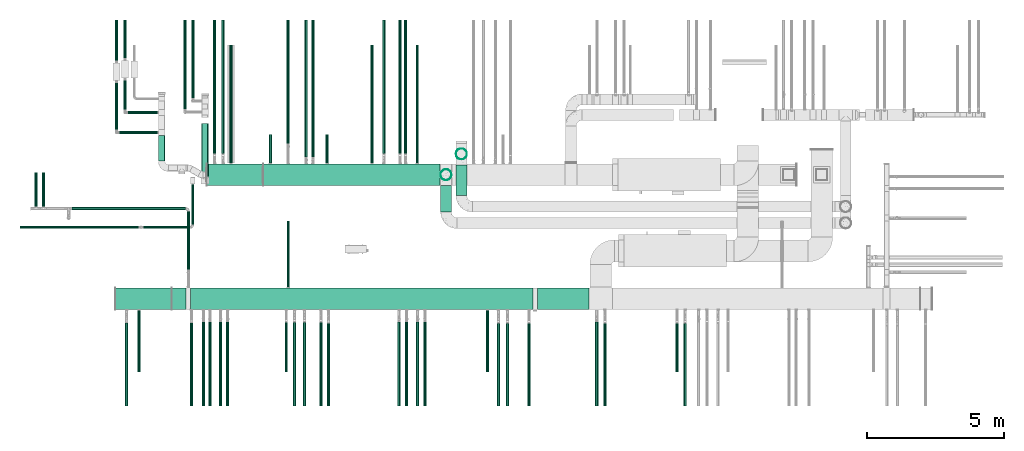
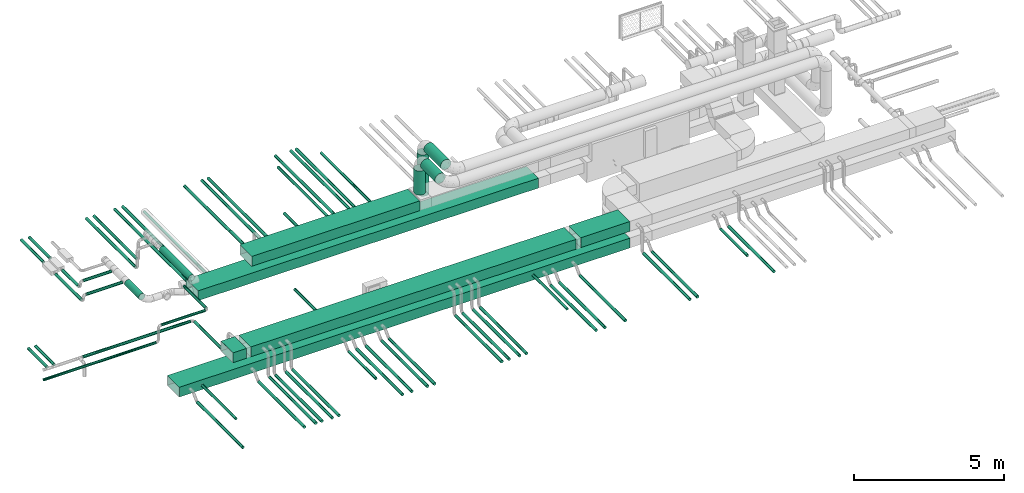
# One storey, part 2 of 91: 65 flow segments.
"""IFC2X3 building model written with IfcOpenShell, lengths in millimetres."""

from ifc_helpers import new_model, entity, si_unit, converted_unit, derived_unit, direction, frame, origin_with_axes, origin_2d_with_axis, place, context, subcontext, project, spatial, hollow_rectangle, hollow_circle, extrude, source, transform, mapped, material, layer, layer_set, layer_usage, type_object, element, save


model = new_model("IFC2X3")

# Units and contexts
model_context = context("Model", 3, precision=1e-05, world=origin_with_axes(), true_north=direction((0.0, 1.0)))
body_context = subcontext(model_context, "Body", "Model", "MODEL_VIEW")
ifc_project = project(units=[si_unit("AREAUNIT", "SQUARE_METRE"), si_unit("VOLUMEUNIT", "CUBIC_METRE", prefix="DECI"), si_unit("TIMEUNIT", "SECOND"), si_unit("THERMODYNAMICTEMPERATUREUNIT", "DEGREE_CELSIUS"), si_unit("PRESSUREUNIT", "PASCAL"), si_unit("MASSUNIT", "GRAM", prefix="KILO"), si_unit("LENGTHUNIT", "METRE", prefix="MILLI"), si_unit("POWERUNIT", "WATT"), si_unit("ELECTRICCURRENTUNIT", "AMPERE"), si_unit("ELECTRICVOLTAGEUNIT", "VOLT"), derived_unit("VOLUMETRICFLOWRATEUNIT", [(si_unit("VOLUMEUNIT", "CUBIC_METRE", prefix="DECI"), 1), (si_unit("TIMEUNIT", "SECOND"), -1)]), derived_unit("LINEARVELOCITYUNIT", [(si_unit("LENGTHUNIT", "METRE"), 1), (si_unit("TIMEUNIT", "SECOND"), -1)]), derived_unit("MASSDENSITYUNIT", [(si_unit("MASSUNIT", "GRAM", prefix="KILO"), 1), (si_unit("VOLUMEUNIT", "CUBIC_METRE"), -1)]), converted_unit("PLANEANGLEUNIT", "DEGREE", entity("IfcRatioMeasure", 0.01745), si_unit("PLANEANGLEUNIT", "RADIAN"), dimensions=[0, 0, 0, 0, 0, 0, 0])], contexts=[model_context])

# Site, building, storey
site_placement = place(None, origin_with_axes())
site = spatial("IfcSite", under=ifc_project, at=site_placement, CompositionType="ELEMENT")
building_placement = place(site_placement, origin_with_axes())
building = spatial("IfcBuilding", under=site, at=building_placement, Name="mc-building", CompositionType="ELEMENT")
storey_placement = place(building_placement, frame((0.0, 0.0, 8700.0), z_axis=(0.0, 0.0, 1.0), x_axis=(1.0, 0.0, 0.0)))
storey = spatial("IfcBuildingStorey", under=building, at=storey_placement, CompositionType="ELEMENT", Elevation=8700.0)

# Flow segments
ifc_material_1 = material(Name="FZ1")
ifc_layer_1 = layer(ifc_material_1, 0.0)
ifc_layer_set_1 = layer_set([ifc_layer_1], Name="FZ1")
ifc_layer_usage_1 = layer_usage(ifc_layer_set_1, "AXIS1", "POSITIVE", 0.0)
duct_segment_type_1 = type_object("IfcDuctSegmentType", PredefinedType="RIGIDSEGMENT")
shared_shape_1 = source(origin_with_axes(), body_context, "Body", "SweptSolid", [
    extrude(hollow_circle(Radius=50.0, WallThickness=2.0, at=origin_2d_with_axis()), frame((0.0, 0.0, 0.0), z_axis=(1.0, 0.0, 0.0), x_axis=(0.0, 1.0, 0.0)), (0.0, 0.0, 1.0), 2257.3),
])
for number, where, z_axis, x_axis in (
    (1, (6000.0, 673.88887, 668.0), (0.0, 0.0, 1.0), (0.0, 1.0, 0.0)),
    (2, (18753.74821, 673.88887, 668.0), (0.0, 0.0, 1.0), (0.0, 1.0, 0.0)),
):
    element("IfcFlowSegment", number, at=place(storey_placement, frame(where, z_axis=z_axis, x_axis=x_axis)), inside=storey, type_object=duct_segment_type_1, material=ifc_layer_usage_1, context=body_context, shape_type="MappedRepresentation", body=[
        mapped(shared_shape_1, transform((0.0, 0.0, 0.0), scale=1.0)),
    ])
shared_shape_2 = source(origin_with_axes(), body_context, "Body", "SweptSolid", [
    extrude(hollow_circle(Radius=55.0, WallThickness=2.0, at=origin_2d_with_axis()), frame((0.0, 0.0, 0.0), z_axis=(1.0, 0.0, 0.0), x_axis=(0.0, 1.0, 0.0)), (0.0, 0.0, 1.0), 2847.2),
])
flow_segment_1_placement = place(storey_placement, frame((7969.21808, 13553.57591, 415.0), z_axis=(0.0, 0.0, 1.0), x_axis=(0.0, -1.0, 0.0)))
element("IfcFlowSegment", 3, at=flow_segment_1_placement, inside=storey, type_object=duct_segment_type_1, material=ifc_layer_usage_1, context=body_context, shape_type="MappedRepresentation", body=[
    mapped(shared_shape_2, transform((0.0, 0.0, 0.0), scale=1.0)),
])
shared_shape_3 = source(origin_with_axes(), body_context, "Body", "SweptSolid", [
    extrude(hollow_circle(Radius=55.0, WallThickness=2.0, at=origin_2d_with_axis()), frame((0.0, 0.0, 0.0), z_axis=(1.0, 0.0, 0.0), x_axis=(0.0, 1.0, 0.0)), (0.0, 0.0, 1.0), 1388.6),
])
flow_segment_2_placement = place(storey_placement, frame((5487.14677, 13553.57591, 415.0), z_axis=(0.0, 0.0, 1.0), x_axis=(0.0, -1.0, 0.0)))
element("IfcFlowSegment", 4, at=flow_segment_2_placement, inside=storey, type_object=duct_segment_type_1, material=ifc_layer_usage_1, context=body_context, shape_type="MappedRepresentation", body=[
    mapped(shared_shape_3, transform((0.0, 0.0, 0.0), scale=1.0)),
])
ifc_material_2 = material(Name="1")
ifc_layer_2 = layer(ifc_material_2, 0.0)
ifc_layer_set_2 = layer_set([ifc_layer_2], Name="1")
ifc_layer_usage_2 = layer_usage(ifc_layer_set_2, "AXIS1", "POSITIVE", 0.0)
duct_segment_type_2 = type_object("IfcDuctSegmentType", PredefinedType="RIGIDSEGMENT")
shared_shape_4 = source(origin_with_axes(), body_context, "Body", "SweptSolid", [
    extrude(hollow_rectangle(XDim=800.0, YDim=400.0, WallThickness=2.0, at=origin_2d_with_axis()), frame((0.0, 0.0, 0.0), z_axis=(1.0, 0.0, 0.0), x_axis=(0.0, 1.0, 0.0)), (0.0, 0.0, 1.0), 12528.3),
])
flow_segment_3_placement = place(storey_placement, frame((20412.5937, 3351.20513, 1344.0), z_axis=(0.0, 0.0, 1.0), x_axis=(-1.0, 0.0, 0.0)))
element("IfcFlowSegment", 5, at=flow_segment_3_placement, inside=storey, type_object=duct_segment_type_2, material=ifc_layer_usage_2, context=body_context, shape_type="MappedRepresentation", body=[
    mapped(shared_shape_4, transform((0.0, 0.0, 0.0), scale=1.0)),
])
shared_shape_5 = source(origin_with_axes(), body_context, "Body", "SweptSolid", [
    extrude(hollow_rectangle(XDim=800.0, YDim=400.0, WallThickness=2.0, at=origin_2d_with_axis()), frame((0.0, 0.0, 0.0), z_axis=(1.0, 0.0, 0.0), x_axis=(0.0, 1.0, 0.0)), (0.0, 0.0, 1.0), 17341.2),
])
flow_segment_4_placement = place(storey_placement, frame((22475.0, 3351.20513, 668.0), z_axis=(0.0, 0.0, 1.0), x_axis=(-1.0, 0.0, 0.0)))
element("IfcFlowSegment", 6, at=flow_segment_4_placement, inside=storey, type_object=duct_segment_type_2, material=ifc_layer_usage_2, context=body_context, shape_type="MappedRepresentation", body=[
    mapped(shared_shape_5, transform((0.0, 0.0, 0.0), scale=1.0)),
])
shared_shape_6 = source(origin_with_axes(), body_context, "Body", "SweptSolid", [
    extrude(hollow_circle(Radius=55.0, WallThickness=2.0, at=origin_2d_with_axis()), frame((0.0, 0.0, 0.0), z_axis=(1.0, 0.0, 0.0), x_axis=(0.0, 1.0, 0.0)), (0.0, 0.0, 1.0), 1699.9),
])
flow_segment_5_placement = place(storey_placement, frame((5177.14677, 11247.78475, 415.0), z_axis=(0.0, 0.0, 1.0), x_axis=(0.0, -1.0, 0.0)))
element("IfcFlowSegment", 7, at=flow_segment_5_placement, inside=storey, type_object=duct_segment_type_1, material=ifc_layer_usage_1, context=body_context, shape_type="MappedRepresentation", body=[
    mapped(shared_shape_6, transform((0.0, 0.0, 0.0), scale=1.0)),
])
shared_shape_7 = source(origin_with_axes(), body_context, "Body", "SweptSolid", [
    extrude(hollow_circle(Radius=55.0, WallThickness=2.0, at=origin_2d_with_axis()), frame((0.0, 0.0, 0.0), z_axis=(1.0, 0.0, 0.0), x_axis=(0.0, 1.0, 0.0)), (0.0, 0.0, 1.0), 3261.5),
])
flow_segment_6_placement = place(storey_placement, frame((7686.9773, 13553.57591, 415.0), z_axis=(0.0, 0.0, 1.0), x_axis=(0.0, -1.0, 0.0)))
element("IfcFlowSegment", 8, at=flow_segment_6_placement, inside=storey, type_object=duct_segment_type_1, material=ifc_layer_usage_1, context=body_context, shape_type="MappedRepresentation", body=[
    mapped(shared_shape_7, transform((0.0, 0.0, 0.0), scale=1.0)),
])
shared_shape_8 = source(origin_with_axes(), body_context, "Body", "SweptSolid", [
    extrude(hollow_circle(Radius=55.0, WallThickness=2.0, at=origin_2d_with_axis()), frame((0.0, 0.0, 0.0), z_axis=(1.0, 0.0, 0.0), x_axis=(0.0, 1.0, 0.0)), (0.0, 0.0, 1.0), 4524.7),
])
flow_segment_7_placement = place(storey_placement, frame((11458.64544, 13553.57591, 415.0), z_axis=(0.0, 0.0, 1.0), x_axis=(0.0, -1.0, 0.0)))
element("IfcFlowSegment", 9, at=flow_segment_7_placement, inside=storey, type_object=duct_segment_type_1, material=ifc_layer_usage_1, context=body_context, shape_type="MappedRepresentation", body=[
    mapped(shared_shape_8, transform((0.0, 0.0, 0.0), scale=1.0)),
])
shared_shape_9 = source(origin_with_axes(), body_context, "Body", "SweptSolid", [
    extrude(hollow_circle(Radius=55.0, WallThickness=2.0, at=origin_2d_with_axis()), frame((0.0, 0.0, 0.0), z_axis=(1.0, 0.0, 0.0), x_axis=(0.0, 1.0, 0.0)), (0.0, 0.0, 1.0), 4886.1),
])
for number, where, z_axis, x_axis in (
    (10, (9076.57414, 13553.57591, 415.0), (0.0, 0.0, 1.0), (0.0, -1.0, 0.0)),
    (11, (8766.57414, 13553.57591, 415.0), (0.0, 0.0, 1.0), (0.0, -1.0, 0.0)),
    (12, (15757.14677, 13553.57591, 415.0), (0.0, 0.0, 1.0), (0.0, -1.0, 0.0)),
    (13, (14957.14677, 13553.57591, 415.0), (0.0, 0.0, 1.0), (0.0, -1.0, 0.0)),
    (14, (15552.24709, 13553.57591, 415.0), (0.0, 0.0, 1.0), (0.0, -1.0, 0.0)),
):
    element("IfcFlowSegment", number, at=place(storey_placement, frame(where, z_axis=z_axis, x_axis=x_axis)), inside=storey, type_object=duct_segment_type_1, material=ifc_layer_usage_1, context=body_context, shape_type="MappedRepresentation", body=[
        mapped(shared_shape_9, transform((0.0, 0.0, 0.0), scale=1.0)),
    ])
shared_shape_10 = source(origin_with_axes(), body_context, "Body", "SweptSolid", [
    extrude(hollow_circle(Radius=55.0, WallThickness=2.0, at=origin_2d_with_axis()), frame((0.0, 0.0, 0.0), z_axis=(1.0, 0.0, 0.0), x_axis=(0.0, 1.0, 0.0)), (0.0, 0.0, 1.0), 5017.0),
])
for number, where, z_axis, x_axis in (
    (15, (12366.76802, 13553.57591, 415.0), (0.0, 0.0, 1.0), (0.0, -1.0, 0.0)),
    (16, (12119.2372, 13553.57591, 415.0), (0.0, 0.0, 1.0), (0.0, -1.0, 0.0)),
):
    element("IfcFlowSegment", number, at=place(storey_placement, frame(where, z_axis=z_axis, x_axis=x_axis)), inside=storey, type_object=duct_segment_type_1, material=ifc_layer_usage_1, context=body_context, shape_type="MappedRepresentation", body=[
        mapped(shared_shape_10, transform((0.0, 0.0, 0.0), scale=1.0)),
    ])
shared_shape_11 = source(origin_with_axes(), body_context, "Body", "SweptSolid", [
    extrude(hollow_circle(Radius=55.0, WallThickness=2.0, at=origin_2d_with_axis()), frame((0.0, 0.0, 0.0), z_axis=(1.0, 0.0, 0.0), x_axis=(0.0, 1.0, 0.0)), (0.0, 0.0, 1.0), 3080.0),
])
for number, where, z_axis, x_axis in (
    (17, (22753.47863, -577.64676, 415.0), (0.0, 0.0, 1.0), (0.0, 1.0, 0.0)),
    (18, (15796.4103, -577.64676, 415.0), (0.0, 0.0, 1.0), (0.0, 1.0, 0.0)),
    (19, (8987.56202, -577.64676, 415.0), (0.0, 0.0, 1.0), (0.0, 1.0, 0.0)),
    (20, (16200.78197, -577.64676, 415.0), (0.0, 0.0, 1.0), (0.0, 1.0, 0.0)),
    (21, (8592.78509, -577.64676, 415.0), (0.0, 0.0, 1.0), (0.0, 1.0, 0.0)),
    (22, (9245.0, -577.64676, 415.0), (0.0, 0.0, 1.0), (0.0, 1.0, 0.0)),
    (23, (8357.82156, -577.64676, 415.0), (0.0, 0.0, 1.0), (0.0, 1.0, 0.0)),
    (24, (16466.11947, -577.64676, 415.0), (0.0, 0.0, 1.0), (0.0, 1.0, 0.0)),
    (25, (15517.82156, -577.64676, 415.0), (0.0, 0.0, 1.0), (0.0, 1.0, 0.0)),
):
    element("IfcFlowSegment", number, at=place(storey_placement, frame(where, z_axis=z_axis, x_axis=x_axis)), inside=storey, type_object=duct_segment_type_1, material=ifc_layer_usage_1, context=body_context, shape_type="MappedRepresentation", body=[
        mapped(shared_shape_11, transform((0.0, 0.0, 0.0), scale=1.0)),
    ])
shared_shape_12 = source(origin_with_axes(), body_context, "Body", "SweptSolid", [
    extrude(hollow_circle(Radius=55.0, WallThickness=2.0, at=origin_2d_with_axis()), frame((0.0, 0.0, 0.0), z_axis=(1.0, 0.0, 0.0), x_axis=(0.0, 1.0, 0.0)), (0.0, 0.0, 1.0), 3019.6),
])
for number, where, z_axis, x_axis in (
    (26, (25991.68775, -577.64676, 415.0), (0.0, 0.0, 1.0), (0.0, 1.0, 0.0)),
    (27, (23048.85991, -577.64676, 415.0), (0.0, 0.0, 1.0), (0.0, 1.0, 0.0)),
    (28, (19483.88525, -577.64676, 415.0), (0.0, 0.0, 1.0), (0.0, 1.0, 0.0)),
    (29, (19148.85991, -577.64676, 415.0), (0.0, 0.0, 1.0), (0.0, 1.0, 0.0)),
    (30, (20273.93073, -577.64676, 415.0), (0.0, 0.0, 1.0), (0.0, 1.0, 0.0)),
):
    element("IfcFlowSegment", number, at=place(storey_placement, frame(where, z_axis=z_axis, x_axis=x_axis)), inside=storey, type_object=duct_segment_type_1, material=ifc_layer_usage_1, context=body_context, shape_type="MappedRepresentation", body=[
        mapped(shared_shape_12, transform((0.0, 0.0, 0.0), scale=1.0)),
    ])
shared_shape_13 = source(origin_with_axes(), body_context, "Body", "SweptSolid", [
    extrude(hollow_circle(Radius=55.0, WallThickness=2.0, at=origin_2d_with_axis()), frame((0.0, 0.0, 0.0), z_axis=(1.0, 0.0, 0.0), x_axis=(0.0, 1.0, 0.0)), (0.0, 0.0, 1.0), 3051.7),
])
for number, where, z_axis, x_axis in (
    (31, (12653.05388, -577.64676, 415.0), (0.0, 0.0, 1.0), (0.0, 1.0, 0.0)),
    (32, (12053.05418, -577.64676, 415.0), (0.0, 0.0, 1.0), (0.0, 1.0, 0.0)),
    (33, (11692.81055, -577.64676, 415.0), (0.0, 0.0, 1.0), (0.0, 1.0, 0.0)),
):
    element("IfcFlowSegment", number, at=place(storey_placement, frame(where, z_axis=z_axis, x_axis=x_axis)), inside=storey, type_object=duct_segment_type_1, material=ifc_layer_usage_1, context=body_context, shape_type="MappedRepresentation", body=[
        mapped(shared_shape_13, transform((0.0, 0.0, 0.0), scale=1.0)),
    ])
shared_shape_14 = source(origin_with_axes(), body_context, "Body", "SweptSolid", [
    extrude(hollow_circle(Radius=55.0, WallThickness=2.0, at=origin_2d_with_axis()), frame((0.0, 0.0, 0.0), z_axis=(1.0, 0.0, 0.0), x_axis=(0.0, 1.0, 0.0)), (0.0, 0.0, 1.0), 3035.1),
])
for number, where, z_axis, x_axis in (
    (34, (7914.47808, -577.64676, 415.0), (0.0, 0.0, 1.0), (0.0, 1.0, 0.0)),
    (35, (5548.85991, -577.64676, 415.0), (0.0, 0.0, 1.0), (0.0, 1.0, 0.0)),
):
    element("IfcFlowSegment", number, at=place(storey_placement, frame(where, z_axis=z_axis, x_axis=x_axis)), inside=storey, type_object=duct_segment_type_1, material=ifc_layer_usage_1, context=body_context, shape_type="MappedRepresentation", body=[
        mapped(shared_shape_14, transform((0.0, 0.0, 0.0), scale=1.0)),
    ])
shared_shape_15 = source(origin_with_axes(), body_context, "Body", "SweptSolid", [
    extrude(hollow_circle(Radius=55.0, WallThickness=2.0, at=origin_2d_with_axis()), frame((0.0, 0.0, 0.0), z_axis=(1.0, 0.0, 0.0), x_axis=(0.0, 1.0, 0.0)), (0.0, 0.0, 1.0), 3028.4),
])
flow_segment_8_placement = place(storey_placement, frame((12930.40917, -577.64676, 415.0), z_axis=(0.0, 0.0, 1.0), x_axis=(0.0, 1.0, 0.0)))
element("IfcFlowSegment", 36, at=flow_segment_8_placement, inside=storey, type_object=duct_segment_type_1, material=ifc_layer_usage_1, context=body_context, shape_type="MappedRepresentation", body=[
    mapped(shared_shape_15, transform((0.0, 0.0, 0.0), scale=1.0)),
])
shared_shape_16 = source(origin_with_axes(), body_context, "Body", "SweptSolid", [
    extrude(hollow_circle(Radius=50.0, WallThickness=2.0, at=origin_2d_with_axis()), frame((0.0, 0.0, 0.0), z_axis=(1.0, 0.0, 0.0), x_axis=(0.0, 1.0, 0.0)), (0.0, 0.0, 1.0), 4323.1),
])
for number, where, z_axis, x_axis in (
    (37, (9369.95588, 12633.41275, 668.0), (0.0, 0.0, 1.0), (0.0, -1.0, 0.0)),
    (38, (14528.37491, 12633.41275, 668.0), (0.0, 0.0, 1.0), (0.0, -1.0, 0.0)),
    (39, (16184.13421, 12633.41275, 668.0), (0.0, 0.0, 1.0), (0.0, -1.0, 0.0)),
):
    element("IfcFlowSegment", number, at=place(storey_placement, frame(where, z_axis=z_axis, x_axis=x_axis)), inside=storey, type_object=duct_segment_type_1, material=ifc_layer_usage_1, context=body_context, shape_type="MappedRepresentation", body=[
        mapped(shared_shape_16, transform((0.0, 0.0, 0.0), scale=1.0)),
    ])
shared_shape_17 = source(origin_with_axes(), body_context, "Body", "SweptSolid", [
    extrude(hollow_circle(Radius=50.0, WallThickness=2.0, at=origin_2d_with_axis()), frame((0.0, 0.0, 0.0), z_axis=(1.0, 0.0, 0.0), x_axis=(0.0, 1.0, 0.0)), (0.0, 0.0, 1.0), 1777.2),
])
flow_segment_9_placement = place(storey_placement, frame((25689.63788, 673.88887, 415.0), z_axis=(0.0, 0.0, 1.0), x_axis=(0.0, 1.0, 0.0)))
element("IfcFlowSegment", 40, at=flow_segment_9_placement, inside=storey, type_object=duct_segment_type_1, material=ifc_layer_usage_1, context=body_context, shape_type="MappedRepresentation", body=[
    mapped(shared_shape_17, transform((0.0, 0.0, 0.0), scale=1.0)),
])
shared_shape_18 = source(origin_with_axes(), body_context, "Body", "SweptSolid", [
    extrude(hollow_circle(Radius=55.0, WallThickness=2.0, at=origin_2d_with_axis()), frame((0.0, 0.0, 0.0), z_axis=(1.0, 0.0, 0.0), x_axis=(0.0, 1.0, 0.0)), (0.0, 0.0, 1.0), 1057.3),
])
for number, where, z_axis, x_axis in (
    (41, (10809.16476, 9367.62755, 1344.0), (0.0, 0.0, 1.0), (0.0, -1.0, 0.0)),
    (42, (12881.59664, 9367.62755, 1344.0), (0.0, 0.0, 1.0), (0.0, -1.0, 0.0)),
):
    element("IfcFlowSegment", number, at=place(storey_placement, frame(where, z_axis=z_axis, x_axis=x_axis)), inside=storey, type_object=duct_segment_type_1, material=ifc_layer_usage_1, context=body_context, shape_type="MappedRepresentation", body=[
        mapped(shared_shape_18, transform((0.0, 0.0, 0.0), scale=1.0)),
    ])
shared_shape_19 = source(origin_with_axes(), body_context, "Body", "SweptSolid", [
    extrude(hollow_circle(Radius=50.0, WallThickness=2.0, at=origin_2d_with_axis()), frame((0.0, 0.0, 0.0), z_axis=(1.0, 0.0, 0.0), x_axis=(0.0, 1.0, 0.0)), (0.0, 0.0, 1.0), 2432.8),
])
flow_segment_10_placement = place(storey_placement, frame((11458.64544, 6204.03427, 668.0), z_axis=(0.0, 0.0, 1.0), x_axis=(0.0, -1.0, 0.0)))
element("IfcFlowSegment", 43, at=flow_segment_10_placement, inside=storey, type_object=duct_segment_type_1, material=ifc_layer_usage_1, context=body_context, shape_type="MappedRepresentation", body=[
    mapped(shared_shape_19, transform((0.0, 0.0, 0.0), scale=1.0)),
])
shared_shape_20 = source(origin_with_axes(), body_context, "Body", "SweptSolid", [
    extrude(hollow_circle(Radius=55.0, WallThickness=2.0, at=origin_2d_with_axis()), frame((0.0, 0.0, 0.0), z_axis=(1.0, 0.0, 0.0), x_axis=(0.0, 1.0, 0.0)), (0.0, 0.0, 1.0), 1248.7),
])
for number, where, z_axis, x_axis in (
    (44, (2504.24801, 7979.38441, 415.0), (0.0, 0.0, 1.0), (0.0, -1.0, 0.0)),
    (45, (2232.32005, 6730.69751, 415.0), (0.0, 0.0, 1.0), (0.0, 1.0, 0.0)),
):
    element("IfcFlowSegment", number, at=place(storey_placement, frame(where, z_axis=z_axis, x_axis=x_axis)), inside=storey, type_object=duct_segment_type_1, material=ifc_layer_usage_1, context=body_context, shape_type="MappedRepresentation", body=[
        mapped(shared_shape_20, transform((0.0, 0.0, 0.0), scale=1.0)),
    ])
duct_segment_type_3 = type_object("IfcDuctSegmentType", Name="Safe", PredefinedType="RIGIDSEGMENT")
shared_shape_21 = source(origin_with_axes(), body_context, "Body", "SweptSolid", [
    extrude(hollow_circle(Radius=50.0, WallThickness=2.0, at=origin_2d_with_axis()), frame((0.0, 0.0, 0.0), z_axis=(1.0, 0.0, 0.0), x_axis=(0.0, 1.0, 0.0)), (0.0, 0.0, 1.0), 1809.3),
])
flow_segment_11_placement = place(storey_placement, frame((11390.97051, 673.88887, 415.0), z_axis=(0.0, 0.0, 1.0), x_axis=(0.0, 1.0, 0.0)))
element("IfcFlowSegment", 46, at=flow_segment_11_placement, inside=storey, type_object=duct_segment_type_3, material=ifc_layer_usage_1, Name="Safe", context=body_context, shape_type="MappedRepresentation", body=[
    mapped(shared_shape_21, transform((0.0, 0.0, 0.0), scale=1.0)),
])
shared_shape_22 = source(origin_with_axes(), body_context, "Body", "SweptSolid", [
    extrude(hollow_rectangle(XDim=800.0, YDim=400.0, WallThickness=2.0, at=origin_2d_with_axis()), frame((0.0, 0.0, 0.0), z_axis=(1.0, 0.0, 0.0), x_axis=(0.0, 1.0, 0.0)), (0.0, 0.0, 1.0), 6468.8),
])
flow_segment_12_placement = place(storey_placement, frame((17013.01748, 7890.34565, 1344.0), z_axis=(0.0, 0.0, 1.0), x_axis=(-1.0, 0.0, 0.0)))
element("IfcFlowSegment", 47, at=flow_segment_12_placement, inside=storey, type_object=duct_segment_type_2, material=ifc_layer_usage_2, context=body_context, shape_type="MappedRepresentation", body=[
    mapped(shared_shape_22, transform((0.0, 0.0, 0.0), scale=1.0)),
])
shared_shape_23 = source(origin_with_axes(), body_context, "Body", "SweptSolid", [
    extrude(hollow_circle(Radius=200.0, WallThickness=2.0, at=origin_2d_with_axis()), frame((0.0, 0.0, 0.0), z_axis=(1.0, 0.0, 0.0), x_axis=(0.0, 1.0, 0.0)), (0.0, 0.0, 1.0), 977.1),
])
flow_segment_13_placement = place(storey_placement, frame((17238.01748, 7890.34565, 1594.0), z_axis=(-1.0, 0.0, 0.0), x_axis=(0.0, 0.0, 1.0)))
element("IfcFlowSegment", 48, at=flow_segment_13_placement, inside=storey, type_object=duct_segment_type_3, material=ifc_layer_usage_1, Name="Safe", context=body_context, shape_type="MappedRepresentation", body=[
    mapped(shared_shape_23, transform((0.0, 0.0, 0.0), scale=1.0)),
])
shared_shape_24 = source(origin_with_axes(), body_context, "Body", "SweptSolid", [
    extrude(hollow_circle(Radius=200.0, WallThickness=2.0, at=origin_2d_with_axis()), frame((0.0, 0.0, 0.0), z_axis=(1.0, 0.0, 0.0), x_axis=(0.0, 1.0, 0.0)), (0.0, 0.0, 1.0), 969.4),
])
flow_segment_14_placement = place(storey_placement, frame((17238.01748, 6520.95522, 2971.08071), z_axis=(0.0, 0.0, 1.0), x_axis=(0.0, 1.0, 0.0)))
element("IfcFlowSegment", 49, at=flow_segment_14_placement, inside=storey, type_object=duct_segment_type_3, material=ifc_layer_usage_1, Name="Safe", context=body_context, shape_type="MappedRepresentation", body=[
    mapped(shared_shape_24, transform((0.0, 0.0, 0.0), scale=1.0)),
])
shared_shape_25 = source(origin_with_axes(), body_context, "Body", "SweptSolid", [
    extrude(hollow_circle(Radius=200.0, WallThickness=2.0, at=origin_2d_with_axis()), frame((0.0, 0.0, 0.0), z_axis=(1.0, 0.0, 0.0), x_axis=(0.0, 1.0, 0.0)), (0.0, 0.0, 1.0), 1683.1),
])
flow_segment_15_placement = place(storey_placement, frame((17800.0, 8648.99645, 888.0), z_axis=(0.0, -1.0, 0.0), x_axis=(0.0, 0.0, 1.0)))
element("IfcFlowSegment", 50, at=flow_segment_15_placement, inside=storey, type_object=duct_segment_type_3, material=ifc_layer_usage_1, Name="Safe", context=body_context, shape_type="MappedRepresentation", body=[
    mapped(shared_shape_25, transform((0.0, 0.0, 0.0), scale=1.0)),
])
shared_shape_26 = source(origin_with_axes(), body_context, "Body", "SweptSolid", [
    extrude(hollow_circle(Radius=200.0, WallThickness=2.0, at=origin_2d_with_axis()), frame((0.0, 0.0, 0.0), z_axis=(1.0, 0.0, 0.0), x_axis=(0.0, 1.0, 0.0)), (0.0, 0.0, 1.0), 1128.0),
])
flow_segment_16_placement = place(storey_placement, frame((17800.0, 8248.99645, 2971.08071), z_axis=(0.0, 0.0, 1.0), x_axis=(0.0, -1.0, 0.0)))
element("IfcFlowSegment", 51, at=flow_segment_16_placement, inside=storey, type_object=duct_segment_type_3, material=ifc_layer_usage_1, Name="Safe", context=body_context, shape_type="MappedRepresentation", body=[
    mapped(shared_shape_26, transform((0.0, 0.0, 0.0), scale=1.0)),
])
shared_shape_27 = source(origin_with_axes(), body_context, "Body", "SweptSolid", [
    extrude(hollow_circle(Radius=125.0, WallThickness=2.0, at=origin_2d_with_axis()), frame((0.0, 0.0, 0.0), z_axis=(1.0, 0.0, 0.0), x_axis=(0.0, 1.0, 0.0)), (0.0, 0.0, 1.0), 1942.4),
])
flow_segment_17_placement = place(storey_placement, frame((8419.02679, 7825.18604, 1214.30701), z_axis=(0.0, 0.0, 1.0), x_axis=(0.0, 1.0, 0.0)))
element("IfcFlowSegment", 52, at=flow_segment_17_placement, inside=storey, type_object=duct_segment_type_3, material=ifc_layer_usage_1, Name="Safe", context=body_context, shape_type="MappedRepresentation", body=[
    mapped(shared_shape_27, transform((0.0, 0.0, 0.0), scale=1.0)),
])
shared_shape_28 = source(origin_with_axes(), body_context, "Body", "SweptSolid", [
    extrude(hollow_rectangle(XDim=800.0, YDim=400.0, WallThickness=2.0, at=origin_2d_with_axis()), frame((0.0, 0.0, 0.0), z_axis=(1.0, 0.0, 0.0), x_axis=(0.0, 1.0, 0.0)), (0.0, 0.0, 1.0), 13103.5),
])
flow_segment_18_placement = place(storey_placement, frame((21585.56538, 7890.34565, 668.0), z_axis=(0.0, 0.0, 1.0), x_axis=(-1.0, 0.0, 0.0)))
element("IfcFlowSegment", 53, at=flow_segment_18_placement, inside=storey, type_object=duct_segment_type_2, material=ifc_layer_usage_2, context=body_context, shape_type="MappedRepresentation", body=[
    mapped(shared_shape_28, transform((0.0, 0.0, 0.0), scale=1.0)),
])
shared_shape_29 = source(origin_with_axes(), body_context, "Body", "SweptSolid", [
    extrude(hollow_circle(Radius=125.0, WallThickness=2.0, at=origin_2d_with_axis()), frame((0.0, 0.0, 0.0), z_axis=(1.0, 0.0, 0.0), x_axis=(0.0, 1.0, 0.0)), (0.0, 0.0, 1.0), 944.5),
])
flow_segment_19_placement = place(storey_placement, frame((6828.023, 9327.92738, 668.0), z_axis=(0.0, 0.0, 1.0), x_axis=(0.0, -1.0, 0.0)))
element("IfcFlowSegment", 54, at=flow_segment_19_placement, inside=storey, type_object=duct_segment_type_3, material=ifc_layer_usage_1, Name="Safe", context=body_context, shape_type="MappedRepresentation", body=[
    mapped(shared_shape_29, transform((0.0, 0.0, 0.0), scale=1.0)),
])
shared_shape_30 = source(origin_with_axes(), body_context, "Body", "SweptSolid", [
    extrude(hollow_circle(Radius=55.0, WallThickness=2.0, at=origin_2d_with_axis()), frame((0.0, 0.0, 0.0), z_axis=(1.0, 0.0, 0.0), x_axis=(0.0, 1.0, 0.0)), (0.0, 0.0, 1.0), 1080.9),
])
flow_segment_20_placement = place(storey_placement, frame((6678.023, 10175.43966, 668.0), z_axis=(0.0, 0.0, 1.0), x_axis=(-1.0, 0.0, 0.0)))
element("IfcFlowSegment", 55, at=flow_segment_20_placement, inside=storey, type_object=duct_segment_type_1, material=ifc_layer_usage_1, context=body_context, shape_type="MappedRepresentation", body=[
    mapped(shared_shape_30, transform((0.0, 0.0, 0.0), scale=1.0)),
])
shared_shape_31 = source(origin_with_axes(), body_context, "Body", "SweptSolid", [
    extrude(hollow_circle(Radius=55.0, WallThickness=2.0, at=origin_2d_with_axis()), frame((0.0, 0.0, 0.0), z_axis=(1.0, 0.0, 0.0), x_axis=(0.0, 1.0, 0.0)), (0.0, 0.0, 1.0), 1390.9),
])
flow_segment_21_placement = place(storey_placement, frame((6678.023, 9437.92738, 668.0), z_axis=(0.0, 0.0, 1.0), x_axis=(-1.0, 0.0, 0.0)))
element("IfcFlowSegment", 56, at=flow_segment_21_placement, inside=storey, type_object=duct_segment_type_1, material=ifc_layer_usage_1, context=body_context, shape_type="MappedRepresentation", body=[
    mapped(shared_shape_31, transform((0.0, 0.0, 0.0), scale=1.0)),
])
shared_shape_32 = source(origin_with_axes(), body_context, "Body", "SweptSolid", [
    extrude(hollow_circle(Radius=55.0, WallThickness=2.0, at=origin_2d_with_axis()), frame((0.0, 0.0, 0.0), z_axis=(1.0, 0.0, 0.0), x_axis=(0.0, 1.0, 0.0)), (0.0, 0.0, 1.0), 4147.1),
])
flow_segment_22_placement = place(storey_placement, frame((3547.17999, 6650.69751, 415.0), z_axis=(0.0, 0.0, 1.0), x_axis=(1.0, 0.0, 0.0)))
element("IfcFlowSegment", 57, at=flow_segment_22_placement, inside=storey, type_object=duct_segment_type_1, material=ifc_layer_usage_1, context=body_context, shape_type="MappedRepresentation", body=[
    mapped(shared_shape_32, transform((0.0, 0.0, 0.0), scale=1.0)),
])
shared_shape_33 = source(origin_with_axes(), body_context, "Body", "SweptSolid", [
    extrude(hollow_circle(Radius=55.0, WallThickness=2.0, at=origin_2d_with_axis()), frame((0.0, 0.0, 0.0), z_axis=(1.0, 0.0, 0.0), x_axis=(0.0, 1.0, 0.0)), (0.0, 0.0, 1.0), 2122.7),
])
flow_segment_23_placement = place(storey_placement, frame((7804.24801, 6540.69751, 415.0), z_axis=(0.0, 0.0, 1.0), x_axis=(0.0, -1.0, 0.0)))
element("IfcFlowSegment", 58, at=flow_segment_23_placement, inside=storey, type_object=duct_segment_type_1, material=ifc_layer_usage_1, context=body_context, shape_type="MappedRepresentation", body=[
    mapped(shared_shape_33, transform((0.0, 0.0, 0.0), scale=1.0)),
])
shared_shape_34 = source(origin_with_axes(), body_context, "Body", "SweptSolid", [
    extrude(hollow_rectangle(XDim=800.0, YDim=400.0, WallThickness=2.0, at=origin_2d_with_axis()), frame((0.0, 0.0, 0.0), z_axis=(1.0, 0.0, 0.0), x_axis=(0.0, 1.0, 0.0)), (0.0, 0.0, 1.0), 524.2),
])
flow_segment_24_placement = place(storey_placement, frame((7724.24801, 3351.20513, 1344.0), z_axis=(0.0, 0.0, 1.0), x_axis=(-1.0, 0.0, 0.0)))
element("IfcFlowSegment", 59, at=flow_segment_24_placement, inside=storey, type_object=duct_segment_type_2, material=ifc_layer_usage_2, context=body_context, shape_type="MappedRepresentation", body=[
    mapped(shared_shape_34, transform((0.0, 0.0, 0.0), scale=1.0)),
])
shared_shape_35 = source(origin_with_axes(), body_context, "Body", "SweptSolid", [
    extrude(hollow_circle(Radius=50.0, WallThickness=2.0, at=origin_2d_with_axis()), frame((0.0, 0.0, 0.0), z_axis=(1.0, 0.0, 0.0), x_axis=(0.0, 1.0, 0.0)), (0.0, 0.0, 1.0), 1693.0),
])
flow_segment_25_placement = place(storey_placement, frame((6172.12654, 5964.82923, 1214.3), z_axis=(0.0, 0.0, 1.0), x_axis=(1.0, 0.0, 0.0)))
element("IfcFlowSegment", 60, at=flow_segment_25_placement, inside=storey, type_object=duct_segment_type_3, material=ifc_layer_usage_1, Name="Safe", context=body_context, shape_type="MappedRepresentation", body=[
    mapped(shared_shape_35, transform((0.0, 0.0, 0.0), scale=1.0)),
])
shared_shape_36 = source(origin_with_axes(), body_context, "Body", "SweptSolid", [
    extrude(hollow_circle(Radius=50.0, WallThickness=2.0, at=origin_2d_with_axis()), frame((0.0, 0.0, 0.0), z_axis=(1.0, 0.0, 0.0), x_axis=(0.0, 1.0, 0.0)), (0.0, 0.0, 1.0), 1470.4),
])
flow_segment_26_placement = place(storey_placement, frame((7965.12654, 6064.82923, 1214.3), z_axis=(0.0, 0.0, 1.0), x_axis=(0.0, 1.0, 0.0)))
element("IfcFlowSegment", 61, at=flow_segment_26_placement, inside=storey, type_object=duct_segment_type_3, material=ifc_layer_usage_1, Name="Safe", context=body_context, shape_type="MappedRepresentation", body=[
    mapped(shared_shape_36, transform((0.0, 0.0, 0.0), scale=1.0)),
])
shared_shape_37 = source(origin_with_axes(), body_context, "Body", "SweptSolid", [
    extrude(hollow_circle(Radius=50.0, WallThickness=2.0, at=origin_2d_with_axis()), frame((0.0, 0.0, 0.0), z_axis=(1.0, 0.0, 0.0), x_axis=(0.0, 1.0, 0.0)), (0.0, 0.0, 1.0), 4329.5),
])
flow_segment_27_placement = place(storey_placement, frame((1642.6599, 5964.82923, 567.67141), z_axis=(0.0, 0.0, 1.0), x_axis=(1.0, 0.0, 0.0)))
element("IfcFlowSegment", 62, at=flow_segment_27_placement, inside=storey, type_object=duct_segment_type_3, material=ifc_layer_usage_1, Name="Safe", context=body_context, shape_type="MappedRepresentation", body=[
    mapped(shared_shape_37, transform((0.0, 0.0, 0.0), scale=1.0)),
])
shared_shape_38 = source(origin_with_axes(), body_context, "Body", "SweptSolid", [
    extrude(hollow_circle(Radius=55.0, WallThickness=2.0, at=origin_2d_with_axis()), frame((0.0, 0.0, 0.0), z_axis=(1.0, 0.0, 0.0), x_axis=(0.0, 1.0, 0.0)), (0.0, 0.0, 1.0), 1479.8),
])
flow_segment_28_placement = place(storey_placement, frame((5177.14677, 12073.78475, 415.0), z_axis=(0.0, 0.0, 1.0), x_axis=(0.0, 1.0, 0.0)))
element("IfcFlowSegment", 63, at=flow_segment_28_placement, inside=storey, type_object=duct_segment_type_1, material=ifc_layer_usage_1, context=body_context, shape_type="MappedRepresentation", body=[
    mapped(shared_shape_38, transform((0.0, 0.0, 0.0), scale=1.0)),
])
shared_shape_39 = source(origin_with_axes(), body_context, "Body", "SweptSolid", [
    extrude(hollow_circle(Radius=55.0, WallThickness=2.0, at=origin_2d_with_axis()), frame((0.0, 0.0, 0.0), z_axis=(1.0, 0.0, 0.0), x_axis=(0.0, 1.0, 0.0)), (0.0, 0.0, 1.0), 1053.5),
])
flow_segment_29_placement = place(storey_placement, frame((5487.14677, 11338.9838, 415.0), z_axis=(0.0, 0.0, 1.0), x_axis=(0.0, -1.0, 0.0)))
element("IfcFlowSegment", 64, at=flow_segment_29_placement, inside=storey, type_object=duct_segment_type_1, material=ifc_layer_usage_1, context=body_context, shape_type="MappedRepresentation", body=[
    mapped(shared_shape_39, transform((0.0, 0.0, 0.0), scale=1.0)),
])
shared_shape_40 = source(origin_with_axes(), body_context, "Body", "SweptSolid", [
    extrude(hollow_rectangle(XDim=800.0, YDim=400.0, WallThickness=2.0, at=origin_2d_with_axis()), frame((0.0, 0.0, 0.0), z_axis=(1.0, 0.0, 0.0), x_axis=(0.0, 1.0, 0.0)), (0.0, 0.0, 1.0), 1887.4),
])
flow_segment_30_placement = place(storey_placement, frame((20587.5937, 3351.20513, 1344.0), z_axis=(0.0, 0.0, 1.0), x_axis=(1.0, 0.0, 0.0)))
element("IfcFlowSegment", 65, at=flow_segment_30_placement, inside=storey, type_object=duct_segment_type_2, material=ifc_layer_usage_2, context=body_context, shape_type="MappedRepresentation", body=[
    mapped(shared_shape_40, transform((0.0, 0.0, 0.0), scale=1.0)),
])

save(model, "model.ifc")
